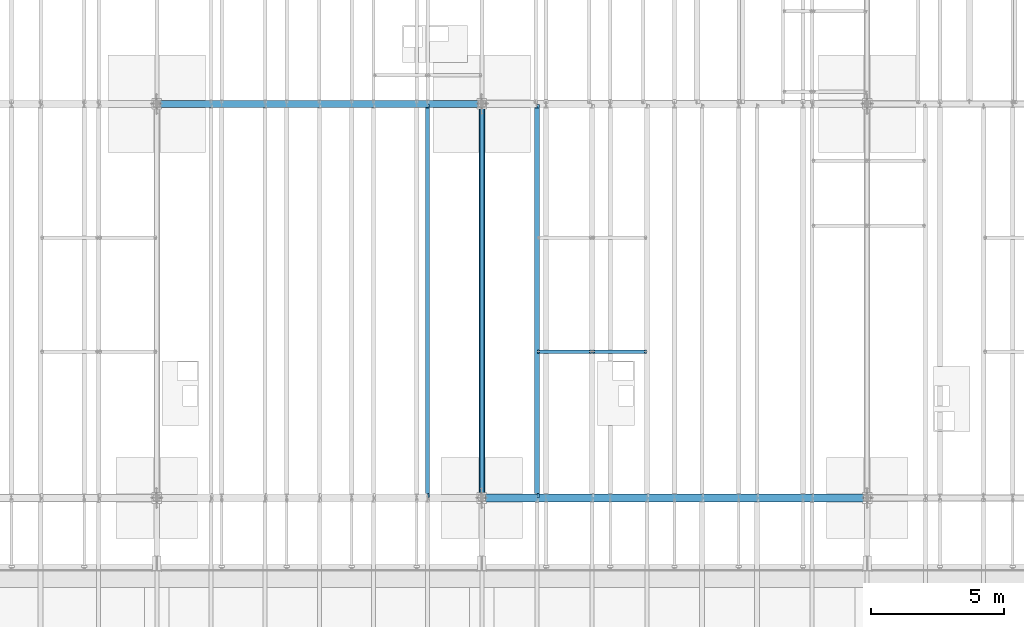
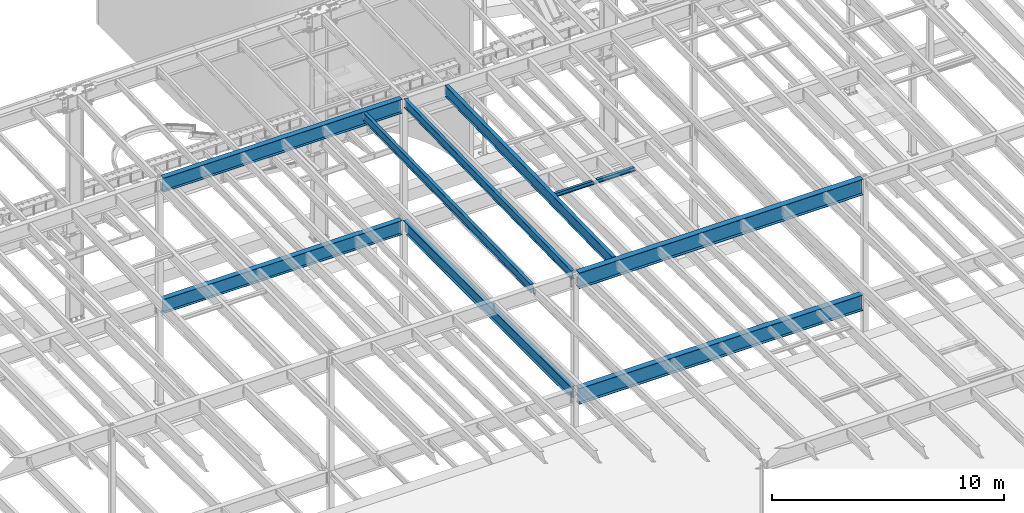
# One storey, part 1106 of 1763: 10 beams, 10 elements without a shape of their own.
"""IFC2X3 building model written with IfcOpenShell, lengths in millimetres."""

from ifc_helpers import new_model, si_unit, frame, origin_with_axes, place, context, subcontext, project, spatial, faceted_brep, material, type_object, element, aggregate, save


model = new_model("IFC2X3")

# Units and contexts
model_context = context("Model", 3, precision=1e-05, world=origin_with_axes())
body_context = subcontext(model_context, "Body", "Model", "MODEL_VIEW")
ifc_project = project(units=[si_unit("LENGTHUNIT", "METRE", prefix="MILLI"), si_unit("AREAUNIT", "SQUARE_METRE"), si_unit("VOLUMEUNIT", "CUBIC_METRE"), si_unit("MASSUNIT", "GRAM", prefix="KILO"), si_unit("TIMEUNIT", "SECOND"), si_unit("PLANEANGLEUNIT", "RADIAN"), si_unit("SOLIDANGLEUNIT", "STERADIAN"), si_unit("THERMODYNAMICTEMPERATUREUNIT", "DEGREE_CELSIUS"), si_unit("LUMINOUSINTENSITYUNIT", "LUMEN")], contexts=[model_context])

# Site, building, storey
site_placement = place(None, origin_with_axes())
site = spatial("IfcSite", under=ifc_project, at=site_placement, CompositionType="ELEMENT")
building_placement = place(site_placement, origin_with_axes())
building = spatial("IfcBuilding", under=site, at=building_placement, Name="Undefined", CompositionType="ELEMENT")
storey_placement = place(building_placement, origin_with_axes())
storey = spatial("IfcBuildingStorey", under=building, at=storey_placement, Name="Undefined", CompositionType="ELEMENT", Elevation=0.0)

# Assembly, beam
assembly_1_placement = place(storey_placement, origin_with_axes())
assembly_1 = element("IfcElementAssembly", 1, at=assembly_1_placement, inside=storey, Name="BEAM", AssemblyPlace="NOTDEFINED", PredefinedType="RIGID_FRAME")
ifc_material = material(Name="STEEL/A992")
beam_type_1 = type_object("IfcBeamType", Name="W8X18", PredefinedType="NOTDEFINED")
beam_1_placement = place(assembly_1_placement, frame((-45273.1229879841, 35509.199940754, 11300.6242220873), z_axis=(0.0, 0.0, 1.0), x_axis=(1.0, 0.0, 0.0)))
beam_1 = element("IfcBeam", 2, at=beam_1_placement, type_object=beam_type_1, material=ifc_material, Name="BEAM", ObjectType="W8X18", context=body_context, shape_type="Brep", body=[
    faceted_brep([(1968.36438668022, -3.17499999999927, 68.5472455015315), (1968.36438668022, 3.17499999999927, 68.5472455015315), (1967.50340238101, 3.17499999512802, 69.8357995645329), (1967.50340247829, -3.17500000487053, 69.8357994189137), (1972.48456314837, -3.17499999999927, 65.794231601054), (1972.48456314837, 3.17499999999927, 65.794231601054), (1977.34464266642, -3.17500000489963, 64.8275016776788), (1977.34464266644, 3.17499999509891, 64.8275016776788), (2047.19464279684, -3.17500000506698, 64.8275016776788), (2047.19464291749, 3.17499999493157, 64.8275016776788), (1966.77688968111, -3.17500000487053, 70.3212397501684), (1966.77688980176, 3.17499999512802, 70.3212397501684), (1964.02387590129, 3.17499999513529, 74.441416218322), (1964.02387578064, -3.17500000486325, 74.441416218322), (1963.0571459787, 3.17499999514257, 79.3014957363666), (1963.05714585805, -3.17500000485597, 79.3014957363666), (1963.05714465155, -66.675000004856, 103.1875), (1963.05714465155, -66.675000004856, 95.25), (1963.05714585805, -3.17500000485597, 95.25), (1963.0571459787, 3.17499999514257, 95.25), (1963.05714718519, 66.6749999951426, 95.25), (1963.05714718519, 66.6749999951426, 103.1875), (101.599996948244, 3.17500000000018, 95.25), (101.599996948244, 66.6750000000002, 95.25), (101.599996948244, 66.6750000000002, 103.1875), (101.599996948244, -66.6750000000002, 103.1875), (101.599996948244, -66.6750000000002, 95.25), (101.599996948244, -3.17500000000018, 95.25), (101.599996948236, 3.17499999999927, 79.301496189446), (101.599996948236, -3.17499999999927, 79.301496189446), (100.633267025652, 3.17499999999927, 74.4414166713996), (100.633267025652, -3.17499999999927, 74.4414166713996), (97.8802531251713, 3.17499999999927, 70.3212402032459), (97.8802531251713, -3.17499999999927, 70.3212402032459), (97.153740969894, 3.17499999999927, 69.8358003008998), (97.153740969894, -3.17499999999927, 69.8358003008998), (96.2927561769247, 3.17500000000018, 68.5472454911378), (96.2927561769247, -3.17500000000018, 68.5472454911378), (92.1725797087711, 3.17500000000018, 65.7942315906603), (92.1725797087711, -3.17500000000018, 65.7942315906603), (87.3125001907247, 3.17500000000018, 64.8275016680727), (87.3125001907247, -3.17500000000018, 64.8275016680727), (17.4624999999905, 3.17500000000018, 64.8275016680727), (17.4624999999905, -3.17500000000018, 64.8275016680727), (17.4624999999905, 3.17500000000018, -95.25), (17.4624999999905, 66.6750000000002, -95.25), (17.4624999999905, 66.6750000000002, -103.1875), (17.4624999999905, -66.6750000000002, -103.1875), (17.4624999999905, -66.6750000000002, -95.25), (17.4624999999905, -3.17500000000018, -95.25), (2047.19464291749, 3.17499999493157, -95.25), (2047.19464412399, 66.6749999949316, -95.25), (2047.19464412399, 66.6749999949316, -103.1875), (2047.19464159034, -66.675000005067, -103.1875), (2047.19464159034, -66.675000005067, -95.25), (2047.19464279684, -3.17500000506698, -95.25)], [[[0, 1, 2, 3]], [[4, 5, 1, 0]], [[6, 7, 5, 4]], [[8, 9, 7, 6]], [[10, 11, 12, 13]], [[13, 12, 14, 15]], [[16, 17, 18, 15, 14, 19, 20, 21]], [[20, 19, 22, 23]], [[21, 20, 23, 24]], [[16, 21, 24, 25]], [[17, 16, 25, 26]], [[18, 17, 26, 27]], [[25, 24, 23, 22, 28, 29, 27, 26]], [[29, 28, 30, 31]], [[31, 30, 32, 33]], [[33, 32, 34, 35]], [[35, 34, 36, 37]], [[37, 36, 38, 39]], [[39, 38, 40, 41]], [[41, 40, 42, 43]], [[44, 45, 46, 47, 48, 49, 43, 42]], [[45, 44, 50, 51]], [[46, 45, 51, 52]], [[47, 46, 52, 53]], [[48, 47, 53, 54]], [[49, 48, 54, 55]], [[4, 0, 3, 10, 13, 15, 18, 27, 29, 31, 33, 35, 37, 39, 41, 43, 49, 55, 8, 6]], [[11, 10, 3, 2]], [[50, 44, 42, 40, 38, 36, 34, 32, 30, 28, 22, 19, 14, 12, 11, 2, 1, 5, 7, 9]], [[55, 54, 53, 52, 51, 50, 9, 8]]]),
])
aggregate(assembly_1, [beam_1])

assembly_2_placement = place(storey_placement, origin_with_axes())
assembly_2 = element("IfcElementAssembly", 3, at=assembly_2_placement, inside=storey, Name="BEAM", AssemblyPlace="NOTDEFINED", PredefinedType="RIGID_FRAME")
beam_2_placement = place(assembly_2_placement, frame((-47337.7801308412, 35509.2, 11300.6242220873), z_axis=(0.0, 0.0, 1.0), x_axis=(1.0, 0.0, 0.0)))
beam_2 = element("IfcBeam", 4, at=beam_2_placement, type_object=beam_type_1, material=ifc_material, Name="BEAM", ObjectType="W8X18", context=body_context, shape_type="Brep", body=[
    faceted_brep([(1968.36438668022, -3.17499999999927, 68.5472455015315), (1968.36438668022, 3.17499999999927, 68.5472455015315), (1967.50340238101, 3.17499999512802, 69.8357995645329), (1967.50340247829, -3.17500000487053, 69.8357994189137), (1972.48456314837, -3.17499999999927, 65.794231601054), (1972.48456314837, 3.17499999999927, 65.794231601054), (1977.34464266642, -3.17500000489963, 64.8275016776788), (1977.34464266644, 3.17499999509891, 64.8275016776788), (2047.19464279684, -3.17500000506698, 64.8275016776788), (2047.19464291749, 3.17499999493157, 64.8275016776788), (1966.77688968111, -3.17500000487053, 70.3212397501684), (1966.77688980176, 3.17499999512802, 70.3212397501684), (1964.02387590129, 3.17499999513529, 74.441416218322), (1964.02387578064, -3.17500000486325, 74.441416218322), (1963.0571459787, 3.17499999514257, 79.3014957363666), (1963.05714585805, -3.17500000485597, 79.3014957363666), (1963.05714718519, 66.6749999951426, 95.25), (1963.0571459787, 3.17499999514257, 95.25), (101.599996948244, 3.17500000000018, 95.25), (101.599996948244, 66.6750000000002, 95.25), (1963.05714465155, -66.675000004856, 95.25), (1963.05714465155, -66.675000004856, 103.1875), (101.599996948244, -66.6750000000002, 103.1875), (101.599996948244, -66.6750000000002, 95.25), (1963.05714718519, 66.6749999951426, 103.1875), (101.599996948244, 66.6750000000002, 103.1875), (1963.05714585805, -3.17500000485597, 95.25), (101.599996948244, -3.17500000000018, 95.25), (101.599996948236, 3.17499999999927, 79.301496189446), (101.599996948236, -3.17499999999927, 79.301496189446), (100.633267025652, 3.17499999999927, 74.4414166713996), (100.633267025652, -3.17499999999927, 74.4414166713996), (97.8802531251713, 3.17499999999927, 70.3212402032459), (97.8802531251713, -3.17499999999927, 70.3212402032459), (97.153740969894, 3.17499999999927, 69.8358003008998), (97.153740969894, -3.17499999999927, 69.8358003008998), (96.2927561769247, 3.17500000000018, 68.5472454911378), (96.2927561769247, -3.17500000000018, 68.5472454911378), (92.1725797087711, 3.17500000000018, 65.7942315906603), (92.1725797087711, -3.17500000000018, 65.7942315906603), (87.3125001907247, 3.17500000000018, 64.8275016680727), (87.3125001907247, -3.17500000000018, 64.8275016680727), (17.4624999999905, 3.17500000000018, 64.8275016680727), (17.4624999999905, -3.17500000000018, 64.8275016680727), (17.4624999999905, 3.17500000000018, -95.25), (17.4624999999905, 66.6750000000002, -95.25), (17.4624999999905, 66.6750000000002, -103.1875), (17.4624999999905, -66.6750000000002, -103.1875), (17.4624999999905, -66.6750000000002, -95.25), (17.4624999999905, -3.17500000000018, -95.25), (2047.19464291749, 3.17499999493157, -95.25), (2047.19464412399, 66.6749999949316, -95.25), (2047.19464412399, 66.6749999949316, -103.1875), (2047.19464159034, -66.675000005067, -103.1875), (2047.19464159034, -66.675000005067, -95.25), (2047.19464279684, -3.17500000506698, -95.25)], [[[0, 1, 2, 3]], [[4, 5, 1, 0]], [[6, 7, 5, 4]], [[8, 9, 7, 6]], [[10, 11, 12, 13]], [[13, 12, 14, 15]], [[16, 17, 18, 19]], [[20, 21, 22, 23]], [[21, 24, 25, 22]], [[24, 16, 19, 25]], [[21, 20, 26, 15, 14, 17, 16, 24]], [[26, 20, 23, 27]], [[22, 25, 19, 18, 28, 29, 27, 23]], [[29, 28, 30, 31]], [[31, 30, 32, 33]], [[33, 32, 34, 35]], [[35, 34, 36, 37]], [[37, 36, 38, 39]], [[39, 38, 40, 41]], [[41, 40, 42, 43]], [[44, 45, 46, 47, 48, 49, 43, 42]], [[45, 44, 50, 51]], [[46, 45, 51, 52]], [[47, 46, 52, 53]], [[48, 47, 53, 54]], [[49, 48, 54, 55]], [[4, 0, 3, 10, 13, 15, 26, 27, 29, 31, 33, 35, 37, 39, 41, 43, 49, 55, 8, 6]], [[11, 10, 3, 2]], [[50, 44, 42, 40, 38, 36, 34, 32, 30, 28, 18, 17, 14, 12, 11, 2, 1, 5, 7, 9]], [[55, 54, 53, 52, 51, 50, 9, 8]]]),
])
aggregate(assembly_2, [beam_2])

assembly_3_placement = place(storey_placement, origin_with_axes())
assembly_3 = element("IfcElementAssembly", 5, at=assembly_3_placement, inside=storey, Name="BEAM", AssemblyPlace="NOTDEFINED", PredefinedType="RIGID_FRAME")
beam_type_2 = type_object("IfcBeamType", Name="W18X35", PredefinedType="NOTDEFINED")
beam_3_placement = place(assembly_3_placement, frame((-49402.4372736983, 30027.4629676506, 11064.9232324289), z_axis=(0.0, -0.0206852279954837, 0.999786037781472), x_axis=(0.0, 0.999786037781472, 0.0206852279954825)))
beam_3 = element("IfcBeam", 6, at=beam_3_placement, type_object=beam_type_2, material=ifc_material, Name="BEAM", ObjectType="W18X35", context=body_context, shape_type="Brep", body=[
    faceted_brep([(135.16548513544, -76.1999999999971, -225.424999999856), (135.16548513544, 76.1999999999971, -225.424999999856), (14632.1422904328, 76.1999999999971, -225.425000002615), (14632.1422904328, -76.1999999999971, -225.425000002615), (135.395398924404, -76.1999999999971, -214.312499999864), (135.395398924404, -3.96875, -214.312499999864), (144.263502213013, -3.96875, 214.312499999811), (144.263502213013, -76.1999999999971, 214.312499999811), (144.493416001977, -76.1999999999971, 225.424999999803), (144.493416001977, 76.1999999999971, 225.424999999803), (144.263502213013, 76.1999999999971, 214.312499999811), (144.263502213013, 3.96875, 214.312499999811), (135.395398924404, 3.96875, -214.312499999864), (135.395398924404, 76.1999999999971, -214.312499999864), (14632.3722042217, -76.1999999999971, -214.312500002625), (14632.3722042217, -3.96875, -214.312500002625), (14641.2403075104, -3.96875, 214.312499997051), (14641.2403075104, -76.1999999999971, 214.312499997051), (14641.4702212993, -76.1999999999971, 225.424999997043), (14641.4702212993, 76.1999999999971, 225.424999997043), (14641.2403075104, 76.1999999999971, 214.312499997051), (14641.2403075104, 3.96875, 214.312499997051), (14632.3722042217, 3.96875, -214.312500002625), (14632.3722042217, 76.1999999999971, -214.312500002625)], [[[0, 1, 2, 3]], [[0, 4, 5, 6, 7, 8, 9, 10, 11, 12, 13, 1]], [[5, 4, 14, 15]], [[6, 5, 15, 16]], [[7, 6, 16, 17]], [[8, 7, 17, 18]], [[9, 8, 18, 19]], [[10, 9, 19, 20]], [[11, 10, 20, 21]], [[12, 11, 21, 22]], [[13, 12, 22, 23]], [[1, 13, 23, 2]], [[22, 21, 20, 19, 18, 17, 16, 15, 14, 3, 2, 23]], [[4, 0, 3, 14]]]),
])
aggregate(assembly_3, [beam_3])

assembly_4_placement = place(storey_placement, origin_with_axes())
assembly_4 = element("IfcElementAssembly", 7, at=assembly_4_placement, inside=storey, Name="BEAM", AssemblyPlace="NOTDEFINED", PredefinedType="RIGID_FRAME")
beam_4_placement = place(assembly_4_placement, frame((-51434.4372736983, 30027.4629676506, 11064.9232324289), z_axis=(0.0, -0.0206852279954837, 0.999786037781472), x_axis=(0.0, 0.999786037781472, 0.0206852279954825)))
beam_4 = element("IfcBeam", 8, at=beam_4_placement, type_object=beam_type_2, material=ifc_material, Name="BEAM", ObjectType="W18X35", context=body_context, shape_type="Brep", body=[
    faceted_brep([(160.440116083144, 4.26867060238874, -214.312499999869), (160.440116083122, 4.26882632548222, -225.424999999861), (9.72614572745442, 4.26881667977432, -225.424999999832), (9.95605951641846, 4.26866097140737, -214.31249999984), (160.440111479107, 76.1999999999971, -214.312499999869), (160.440111479107, 76.1999999999971, -225.424999999861), (160.440111159907, -3.96875, 187.065001487454), (160.440111159907, 3.96875, 187.065001487454), (159.47338123732, 3.96875, 182.204921969418), (159.47338123732, -3.96875, 182.204921969418), (156.720367336846, 3.96875, 178.084745501274), (156.720367336846, -3.96875, 178.084745501274), (152.600190868703, 3.96875, 175.331731600803), (152.600190868703, -3.96875, 175.331731600803), (147.740111350664, 3.96875, 174.365001678218), (147.740111350664, -3.96875, 174.365001678218), (17.9976628546319, 3.96875, 174.365001678243), (17.9976628546319, -3.96875, 174.365001678243), (9.95605951641846, -3.96875, -214.31249999984), (14757.8115434472, -3.96875, -214.312500002648), (14765.8531467846, -3.96875, 174.36500163611), (14641.5955948759, -3.96875, 174.365001636133), (14636.7355153579, -3.96875, 175.331731558719), (14632.6153388897, -3.96875, 178.084745459191), (14629.8623249892, -3.96875, 182.204921927336), (14628.8955950666, -3.96875, 187.065001445368), (14628.8955950666, -3.96875, 214.312499997053), (160.440111159915, -3.96875, 214.312499999809), (9.95605951641846, -76.1999999999971, -214.31249999984), (14757.8115434472, -76.1999999999971, -214.312500002648), (9.72614572745442, -76.1999999999971, -225.424999999832), (14757.5816296582, -76.1999999999971, -225.425000002639), (14641.5955921487, 4.26882640406257, -214.312500002627), (14641.5955921487, 4.26867068048159, -225.425000002617), (14641.5955830855, 76.1999999999971, -225.425000002617), (14641.5955830855, 76.1999999999971, -214.312500002628), (14757.8115434472, 4.26884104704368, -214.312500002648), (14757.5816296582, 4.26868529446074, -225.425000002639), (14757.8115434472, 3.96875, -214.312500002648), (14765.8531467846, 3.96875, 174.36500163611), (14641.5955948759, 3.96875, 174.365001636133), (14636.7355153579, 3.96875, 175.331731558719), (14632.6153388897, 3.96875, 178.084745459191), (14629.8623249892, 3.96875, 182.204921927336), (14628.8955950666, 3.96875, 187.065001445368), (14628.8955950666, -76.1999999999971, 225.424999997045), (14628.8955950666, -76.1999999999971, 214.312499997053), (14628.8955950666, 3.96875, 214.312499997053), (14628.8955950666, 76.1999999999971, 214.312499997053), (14628.8955950666, 76.1999999999971, 225.424999997045), (160.440111159915, 3.96875, 214.312499999809), (160.440111159915, 76.1999999999971, 214.312499999809), (160.440111159915, 76.1999999999971, 225.424999999799), (160.440111159915, -76.1999999999971, 225.424999999799), (160.440111159915, -76.1999999999971, 214.312499999809), (9.95605951641846, 3.96875, -214.31249999984)], [[[0, 1, 2, 3]], [[4, 5, 1, 0]], [[6, 7, 8, 9]], [[9, 8, 10, 11]], [[11, 10, 12, 13]], [[13, 12, 14, 15]], [[15, 14, 16, 17]], [[9, 11, 13, 15, 17, 18, 19, 20, 21, 22, 23, 24, 25, 26, 27, 6]], [[18, 28, 29, 19]], [[28, 30, 31, 29]], [[32, 33, 34, 35]], [[36, 37, 33, 32]], [[38, 39, 20, 19, 29, 31, 37, 36]], [[20, 39, 40, 21]], [[21, 40, 41, 22]], [[22, 41, 42, 23]], [[23, 42, 43, 24]], [[24, 43, 44, 25]], [[45, 46, 26, 25, 44, 47, 48, 49]], [[48, 47, 50, 51]], [[49, 48, 51, 52]], [[45, 49, 52, 53]], [[46, 45, 53, 54]], [[26, 46, 54, 27]], [[53, 52, 51, 50, 7, 6, 27, 54]], [[47, 44, 43, 42, 41, 40, 39, 38, 55, 16, 14, 12, 10, 8, 7, 50]], [[30, 28, 18, 17, 16, 55, 3, 2]], [[34, 33, 37, 31, 30, 2, 1, 5]], [[35, 34, 5, 4]], [[55, 38, 36, 32, 35, 4, 0, 3]]]),
])
aggregate(assembly_4, [beam_4])

assembly_5_placement = place(storey_placement, origin_with_axes())
assembly_5 = element("IfcElementAssembly", 9, at=assembly_5_placement, inside=storey, Name="BEAM", AssemblyPlace="NOTDEFINED", PredefinedType="RIGID_FRAME")
beam_type_3 = type_object("IfcBeamType", Name="W24X55", PredefinedType="NOTDEFINED")
beam_5_placement = place(assembly_5_placement, frame((-47337.7801308412, 30029.0063442512, 10990.3266966851), z_axis=(0.0, -0.0206852279954837, 0.999786037781472), x_axis=(0.0, 0.999786037781472, 0.0206852279954825)))
beam_5 = element("IfcBeam", 10, at=beam_5_placement, type_object=beam_type_3, material=ifc_material, Name="BEAM", ObjectType="W24X55", context=body_context, shape_type="Brep", body=[
    faceted_brep([(159.690329536948, 5.06237880352273, -287.337499999812), (159.690329536945, 5.06261812614684, -300.037499999804), (7.43265181667448, 5.06260883843788, -300.037499999775), (7.69541043263234, 5.06236953187909, -287.337499999783), (159.690324423107, 88.9000000000015, -287.337499999812), (159.690324423103, 88.9000000000015, -300.037499999802), (159.690324117899, -4.76249999999709, 261.677501487318), (159.690324117899, 4.76249999999709, 261.677501487318), (158.723594195311, 4.76249999999709, 256.817421969285), (158.723594195311, -4.76249999999709, 256.817421969285), (155.970580294834, 4.76249999999709, 252.697245501142), (155.970580294834, -4.76249999999709, 252.697245501142), (151.850403826695, 4.76249999999709, 249.944231600668), (151.850403826695, -4.76249999999709, 249.944231600668), (146.990324308659, 4.76249999999709, 248.977501678084), (146.990324308659, -4.76249999999709, 248.977501678084), (18.7915826813696, 4.76249999999709, 248.97750167811), (18.7915826813696, -4.76249999999709, 248.97750167811), (7.69541043263234, -4.76249999999709, -287.337499999783), (14754.7569745369, -4.76249999999709, -287.337500002592), (14765.8531467848, -4.76249999999709, 248.977501635871), (14640.0518880073, -4.76249999999709, 248.977501635894), (14635.1918084892, -4.76249999999709, 249.944231558482), (14631.0716320211, -4.76249999999709, 252.697245458956), (14628.3186181206, -4.76249999999709, 256.817421927099), (14627.351888198, -4.76249999999709, 261.677501445134), (14627.351888198, -4.76249999999709, 287.337499997), (159.690324117902, -4.76249999999709, 287.337499999756), (7.69541043263234, -88.9000000000015, -287.337499999783), (14754.7569745369, -88.9000000000015, -287.337500002592), (7.43265181667448, -88.9000000000015, -300.037499999775), (14754.4942159209, -88.9000000000015, -300.037500002583), (14640.051883239, 5.06261810508295, -287.33750000257), (14640.051883239, 5.06237878320098, -300.03750000256), (14640.0518719211, 88.9000000000015, -300.037500002562), (14640.0518719211, 88.9000000000015, -287.337500002572), (14754.7569745369, 5.0626335900306, -287.337500002592), (14754.4942159209, 5.06239423266379, -300.037500002583), (14754.7569745369, 4.76249999999709, -287.337500002592), (14765.8531467848, 4.76249999999709, 248.977501635871), (14640.0518880073, 4.76249999999709, 248.977501635894), (14635.1918084892, 4.76249999999709, 249.944231558482), (14631.0716320211, 4.76249999999709, 252.697245458956), (14628.3186181206, 4.76249999999709, 256.817421927099), (14627.351888198, 4.76249999999709, 261.677501445134), (14627.351888198, -88.9000000000015, 300.03749999699), (14627.351888198, -88.9000000000015, 287.337499997), (14627.351888198, 4.76249999999709, 287.337499997), (14627.351888198, 88.9000000000015, 287.337499997), (14627.351888198, 88.9000000000015, 300.03749999699), (159.690324117902, 4.76249999999709, 287.337499999756), (159.690324117902, 88.9000000000015, 287.337499999756), (159.690324117906, 88.9000000000015, 300.037499999746), (159.690324117906, -88.9000000000015, 300.037499999746), (159.690324117902, -88.9000000000015, 287.337499999756), (7.69541043263234, 4.76249999999709, -287.337499999783)], [[[0, 1, 2, 3]], [[4, 5, 1, 0]], [[6, 7, 8, 9]], [[9, 8, 10, 11]], [[11, 10, 12, 13]], [[13, 12, 14, 15]], [[15, 14, 16, 17]], [[9, 11, 13, 15, 17, 18, 19, 20, 21, 22, 23, 24, 25, 26, 27, 6]], [[18, 28, 29, 19]], [[28, 30, 31, 29]], [[32, 33, 34, 35]], [[36, 37, 33, 32]], [[38, 39, 20, 19, 29, 31, 37, 36]], [[20, 39, 40, 21]], [[21, 40, 41, 22]], [[22, 41, 42, 23]], [[23, 42, 43, 24]], [[24, 43, 44, 25]], [[45, 46, 26, 25, 44, 47, 48, 49]], [[48, 47, 50, 51]], [[49, 48, 51, 52]], [[45, 49, 52, 53]], [[46, 45, 53, 54]], [[26, 46, 54, 27]], [[53, 52, 51, 50, 7, 6, 27, 54]], [[47, 44, 43, 42, 41, 40, 39, 38, 55, 16, 14, 12, 10, 8, 7, 50]], [[30, 28, 18, 17, 16, 55, 3, 2]], [[34, 33, 37, 31, 30, 2, 1, 5]], [[35, 34, 5, 4]], [[55, 38, 36, 32, 35, 4, 0, 3]]]),
])
aggregate(assembly_5, [beam_5])

assembly_6_placement = place(storey_placement, origin_with_axes())
assembly_6 = element("IfcElementAssembly", 11, at=assembly_6_placement, inside=storey, Name="BEAM", AssemblyPlace="NOTDEFINED", PredefinedType="RIGID_FRAME")
beam_type_4 = type_object("IfcBeamType", Name="W30X90", PredefinedType="NOTDEFINED")
beam_6_placement = place(assembly_6_placement, frame((-61594.4372736983, 44805.5999999732, 11220.5088409688), z_axis=(0.0, 0.0, 1.0), x_axis=(1.0, 0.0, 0.0)))
beam_6 = element("IfcBeam", 12, at=beam_6_placement, type_object=beam_type_4, material=ifc_material, Name="BEAM", ObjectType="W30X90", context=body_context, shape_type="Brep", body=[
    faceted_brep([(141.287500000006, 131.762500000001, -374.65), (141.287500000006, 131.762500000001, -358.775), (12050.7125, 131.762500000001, -358.775), (12050.7125, 131.762500000001, -374.65), (141.287500000006, 6.34999999999854, -358.775), (12050.7125, 6.34999999999854, -358.775), (141.287500000006, 6.34999999999854, 358.775), (12050.7125, 6.34999999999854, 358.775), (141.287500000006, 131.762500000001, 358.775), (12050.7125, 131.762500000001, 358.775), (141.287500000006, 131.762500000001, 374.65), (12050.7125, 131.762500000001, 374.65), (141.287500000006, -131.762500000001, 374.65), (12050.7125, -131.762500000001, 374.65), (141.287500000006, -131.762500000001, 358.775), (12050.7125, -131.762500000001, 358.775), (141.287500000006, -6.34999999999854, 358.775), (12050.7125, -6.34999999999854, 358.775), (141.287500000006, -6.34999999999854, -358.775), (12050.7125, -6.34999999999854, -358.775), (141.287500000006, -131.762500000001, -358.775), (12050.7125, -131.762500000001, -358.775), (141.287500000006, -131.762500000001, -374.65), (12050.7125, -131.762500000001, -374.65)], [[[0, 1, 2, 3]], [[1, 4, 5, 2]], [[4, 6, 7, 5]], [[6, 8, 9, 7]], [[8, 10, 11, 9]], [[10, 12, 13, 11]], [[12, 14, 15, 13]], [[14, 16, 17, 15]], [[16, 18, 19, 17]], [[18, 20, 21, 19]], [[20, 22, 23, 21]], [[22, 0, 3, 23]], [[5, 7, 9, 11, 13, 15, 17, 19, 21, 23, 3, 2]], [[22, 20, 18, 16, 14, 12, 10, 8, 6, 4, 1, 0]]]),
])
aggregate(assembly_6, [beam_6])

assembly_7_placement = place(storey_placement, origin_with_axes())
assembly_7 = element("IfcElementAssembly", 13, at=assembly_7_placement, inside=storey, Name="BEAM", AssemblyPlace="NOTDEFINED", PredefinedType="RIGID_FRAME")
beam_7_placement = place(assembly_7_placement, frame((-61594.4372736983, 44805.6, 4819.65), z_axis=(0.0, 0.0, 1.0), x_axis=(1.0, 0.0, 0.0)))
beam_7 = element("IfcBeam", 14, at=beam_7_placement, type_object=beam_type_4, material=ifc_material, Name="BEAM", ObjectType="W30X90", context=body_context, shape_type="Brep", body=[
    faceted_brep([(141.287500000006, 131.762500000001, -374.65), (141.287500000006, 131.762500000001, -358.775), (12050.7125, 131.762500000001, -358.775), (12050.7125, 131.762500000001, -374.65), (141.287500000006, 6.34999999999854, -358.775), (12050.7125, 6.34999999999854, -358.775), (141.287500000006, 6.34999999999854, 358.775), (12050.7125, 6.34999999999854, 358.775), (141.287500000006, 131.762500000001, 358.775), (12050.7125, 131.762500000001, 358.775), (141.287500000006, 131.762500000001, 374.65), (12050.7125, 131.762500000001, 374.65), (141.287500000006, -131.762500000001, 374.65), (12050.7125, -131.762500000001, 374.65), (141.287500000006, -131.762500000001, 358.775), (12050.7125, -131.762500000001, 358.775), (141.287500000006, -6.34999999999854, 358.775), (12050.7125, -6.34999999999854, 358.775), (141.287500000006, -6.34999999999854, -358.775), (12050.7125, -6.34999999999854, -358.775), (141.287500000006, -131.762500000001, -358.775), (12050.7125, -131.762500000001, -358.775), (141.287500000006, -131.762500000001, -374.65), (12050.7125, -131.762500000001, -374.65)], [[[0, 1, 2, 3]], [[1, 4, 5, 2]], [[4, 6, 7, 5]], [[6, 8, 9, 7]], [[8, 10, 11, 9]], [[10, 12, 13, 11]], [[12, 14, 15, 13]], [[14, 16, 17, 15]], [[16, 18, 19, 17]], [[18, 20, 21, 19]], [[20, 22, 23, 21]], [[22, 0, 3, 23]], [[5, 7, 9, 11, 13, 15, 17, 19, 21, 23, 3, 2]], [[22, 20, 18, 16, 14, 12, 10, 8, 6, 4, 1, 0]]]),
])
aggregate(assembly_7, [beam_7])

assembly_8_placement = place(storey_placement, origin_with_axes())
assembly_8 = element("IfcElementAssembly", 15, at=assembly_8_placement, inside=storey, Name="BEAM", AssemblyPlace="NOTDEFINED", PredefinedType="RIGID_FRAME")
beam_type_5 = type_object("IfcBeamType", Name="W33X118", PredefinedType="NOTDEFINED")
beam_8_placement = place(assembly_8_placement, frame((-49402.4372736983, 30022.8000001297, 10872.7874999957), z_axis=(0.0, 0.0, 1.0), x_axis=(1.0, 0.0, 0.0)))
beam_8 = element("IfcBeam", 16, at=beam_8_placement, type_object=beam_type_5, material=ifc_material, Name="BEAM", ObjectType="W33X118", context=body_context, shape_type="Brep", body=[
    faceted_brep([(141.287499999999, 146.049999999999, -417.512500000001), (141.287499999999, 146.049999999999, -398.4625), (14311.3125, 146.049999999999, -398.4625), (14311.3125, 146.049999999999, -417.512500000001), (141.287499999999, 7.14374999999927, -398.4625), (14311.3125, 7.14374999999927, -398.4625), (141.287499999999, 7.14374999999927, 398.4625), (14311.3125, 7.14374999999927, 398.4625), (141.287499999999, 146.049999999999, 398.4625), (14311.3125, 146.049999999999, 398.4625), (141.287499999999, 146.049999999999, 417.512500000001), (14311.3125, 146.049999999999, 417.512500000001), (141.287499999999, -146.049999999999, 417.512500000001), (14311.3125, -146.049999999999, 417.512500000001), (141.287499999999, -146.049999999999, 398.4625), (14311.3125, -146.049999999999, 398.4625), (141.287499999999, -7.14374999999927, 398.4625), (14311.3125, -7.14374999999927, 398.4625), (141.287499999999, -7.14374999999927, -398.4625), (14311.3125, -7.14374999999927, -398.4625), (141.287499999999, -146.049999999999, -398.4625), (14311.3125, -146.049999999999, -398.4625), (141.287499999999, -146.049999999999, -417.512500000001), (14311.3125, -146.049999999999, -417.512500000001)], [[[0, 1, 2, 3]], [[1, 4, 5, 2]], [[4, 6, 7, 5]], [[6, 8, 9, 7]], [[8, 10, 11, 9]], [[10, 12, 13, 11]], [[12, 14, 15, 13]], [[14, 16, 17, 15]], [[16, 18, 19, 17]], [[18, 20, 21, 19]], [[20, 22, 23, 21]], [[22, 0, 3, 23]], [[5, 7, 9, 11, 13, 15, 17, 19, 21, 23, 3, 2]], [[22, 20, 18, 16, 14, 12, 10, 8, 6, 4, 1, 0]]]),
])
aggregate(assembly_8, [beam_8])

assembly_9_placement = place(storey_placement, origin_with_axes())
assembly_9 = element("IfcElementAssembly", 17, at=assembly_9_placement, inside=storey, Name="BEAM", AssemblyPlace="NOTDEFINED", PredefinedType="RIGID_FRAME")
beam_9_placement = place(assembly_9_placement, frame((-49402.4372736983, 30022.8, 4776.7875), z_axis=(0.0, 0.0, 1.0), x_axis=(1.0, 0.0, 0.0)))
beam_9 = element("IfcBeam", 18, at=beam_9_placement, type_object=beam_type_5, material=ifc_material, Name="BEAM", ObjectType="W33X118", context=body_context, shape_type="Brep", body=[
    faceted_brep([(141.287499999999, 146.049999999999, -417.512500000001), (141.287499999999, 146.049999999999, -398.4625), (14311.3125, 146.049999999999, -398.4625), (14311.3125, 146.049999999999, -417.512500000001), (141.287499999999, 7.14374999999927, -398.4625), (14311.3125, 7.14374999999927, -398.4625), (141.287499999999, 7.14374999999927, 398.4625), (14311.3125, 7.14374999999927, 398.4625), (141.287499999999, 146.049999999999, 398.4625), (14311.3125, 146.049999999999, 398.4625), (141.287499999999, 146.049999999999, 417.512500000001), (14311.3125, 146.049999999999, 417.512500000001), (141.287499999999, -146.049999999999, 417.512500000001), (14311.3125, -146.049999999999, 417.512500000001), (141.287499999999, -146.049999999999, 398.4625), (14311.3125, -146.049999999999, 398.4625), (141.287499999999, -7.14374999999927, 398.4625), (14311.3125, -7.14374999999927, 398.4625), (141.287499999999, -7.14374999999927, -398.4625), (14311.3125, -7.14374999999927, -398.4625), (141.287499999999, -146.049999999999, -398.4625), (14311.3125, -146.049999999999, -398.4625), (141.287499999999, -146.049999999999, -417.512500000001), (14311.3125, -146.049999999999, -417.512500000001)], [[[0, 1, 2, 3]], [[1, 4, 5, 2]], [[4, 6, 7, 5]], [[6, 8, 9, 7]], [[8, 10, 11, 9]], [[10, 12, 13, 11]], [[12, 14, 15, 13]], [[14, 16, 17, 15]], [[16, 18, 19, 17]], [[18, 20, 21, 19]], [[20, 22, 23, 21]], [[22, 0, 3, 23]], [[5, 7, 9, 11, 13, 15, 17, 19, 21, 23, 3, 2]], [[22, 20, 18, 16, 14, 12, 10, 8, 6, 4, 1, 0]]]),
])
aggregate(assembly_9, [beam_9])

assembly_10_placement = place(storey_placement, origin_with_axes())
assembly_10 = element("IfcElementAssembly", 19, at=assembly_10_placement, inside=storey, Name="BEAM", AssemblyPlace="NOTDEFINED", PredefinedType="RIGID_FRAME")
beam_type_6 = type_object("IfcBeamType", Name="W24X84", PredefinedType="NOTDEFINED")
beam_10_placement = place(assembly_10_placement, frame((-49402.4372736983, 30022.8, 4887.9125), z_axis=(0.0, 0.0, 1.0), x_axis=(0.0, 1.0, 0.0)))
beam_10 = element("IfcBeam", 20, at=beam_10_placement, type_object=beam_type_6, material=ifc_material, Name="BEAM", ObjectType="W24X84", context=body_context, shape_type="Brep", body=[
    faceted_brep([(144.462500000001, -6.65027077648119, -287.3375), (144.462500000001, -6.64991989452392, -306.3875), (398.462548051273, -6.64982312094799, -306.3875), (398.462548051411, -6.65017400289071, -287.3375), (398.462589065799, -114.300000000003, -287.3375), (398.462589065799, -114.300000000003, -306.3875), (144.462500000001, -6.34999999999854, 287.3375), (144.462500000001, -6.34999999999854, -287.3375), (14638.3375, -6.34999999999854, -287.3375), (14638.3375, -6.34999999999854, 287.3375), (144.462500000001, -114.300000000003, 287.3375), (14638.3375, -114.300000000003, 287.3375), (144.462500000001, -114.300000000003, 306.3875), (14638.3375, -114.300000000003, 306.3875), (144.462500000001, 114.300000000003, 306.3875), (14638.3375, 114.300000000003, 306.3875), (144.462500000001, 114.300000000003, 287.3375), (14638.3375, 114.300000000003, 287.3375), (144.462500000001, 6.34999999999854, 287.3375), (14638.3375, 6.34999999999854, 287.3375), (144.462500000001, 6.34999999999854, -287.3375), (14638.3375, 6.34999999999854, -287.3375), (14638.3375, 6.65027077697596, -287.3375), (14384.3374519492, 6.65017400338547, -287.3375), (14384.3374109348, 114.300000000003, -287.3375), (398.462501906062, 114.300000000003, -287.3375), (398.462542919809, 6.64982301944838, -287.3375), (144.462500000001, 6.64972624585062, -287.3375), (398.462542919671, 6.65017390138382, -306.3875), (144.462500000001, 6.65007712780789, -306.3875), (398.462501906062, 114.300000000003, -306.3875), (14384.3374109348, 114.300000000003, -306.3875), (14384.3374519493, 6.64982312144275, -306.3875), (14638.3375, 6.64991989501868, -306.3875), (14638.3375, -6.64972624439542, -287.3375), (14638.3375, -6.6500771263527, -306.3875), (14384.337457085, -6.64982301799319, -287.3375), (14384.3374570851, -6.65017389992863, -306.3875), (14384.3374980991, -114.300000000003, -287.3375), (14384.3374980991, -114.300000000003, -306.3875)], [[[0, 1, 2, 3]], [[4, 3, 2, 5]], [[6, 7, 8, 9]], [[10, 6, 9, 11]], [[12, 10, 11, 13]], [[14, 12, 13, 15]], [[16, 14, 15, 17]], [[18, 16, 17, 19]], [[20, 18, 19, 21]], [[20, 21, 22, 23, 24, 25, 26, 27]], [[26, 28, 29, 27]], [[25, 30, 28, 26]], [[24, 31, 30, 25]], [[23, 32, 31, 24]], [[22, 33, 32, 23]], [[21, 19, 17, 15, 13, 11, 9, 8, 34, 35, 33, 22]], [[34, 36, 37, 35]], [[38, 39, 37, 36]], [[39, 38, 4, 5]], [[1, 29, 28, 30, 31, 32, 33, 35, 37, 39, 5, 2]], [[7, 6, 10, 12, 14, 16, 18, 20, 27, 29, 1, 0]], [[38, 36, 34, 8, 7, 0, 3, 4]]]),
])
aggregate(assembly_10, [beam_10])

save(model, "model.ifc")
